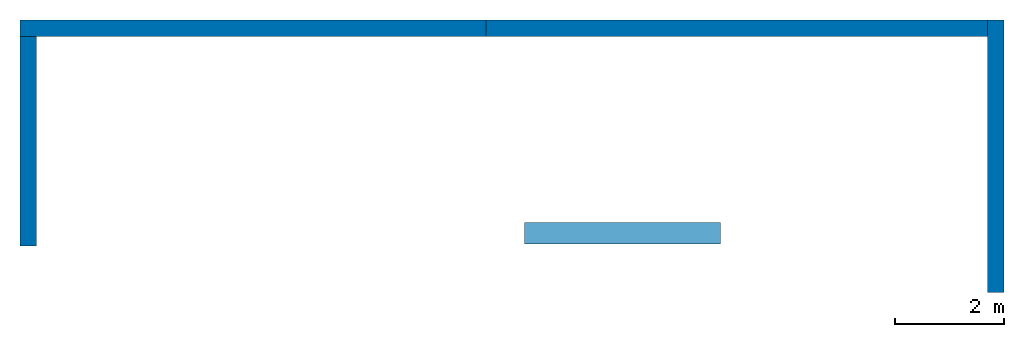
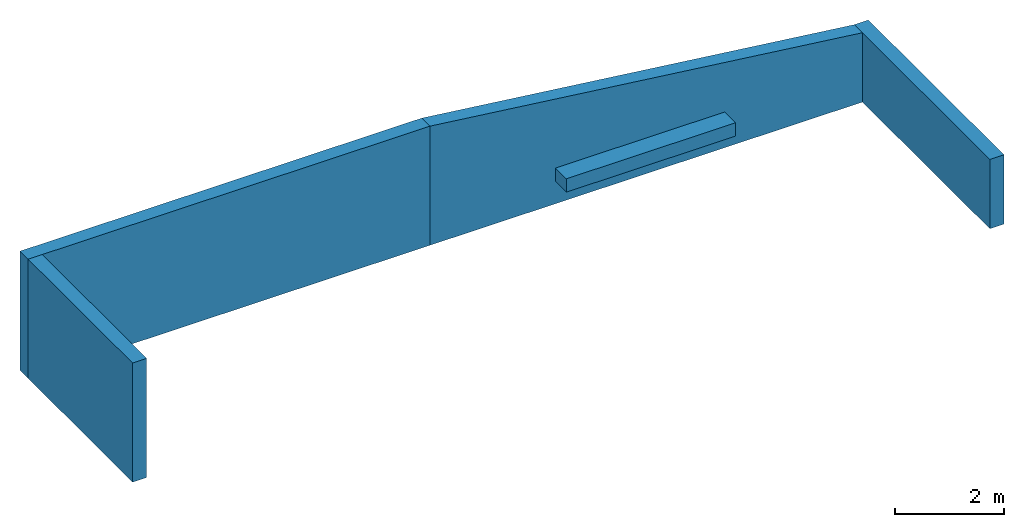
# Not in any storey: 4 walls, 1 beam.
"""IFC4 building model written with IfcOpenShell, lengths in metres."""

from ifc_helpers import new_model, entity, si_unit, converted_unit, direction, frame, frame_2d, origin_with_axes, origin_2d_with_axis, place, context, subcontext, project, spatial, polyline, rectangle, outline, extrude, element, save


model = new_model("IFC4")

# Units and contexts
model_context = context("Model", 3, precision=1e-05, world=origin_with_axes(), true_north=direction((6.12323399573677e-17, 1.0)))
body_context = subcontext(model_context, "Body", "Model", "MODEL_VIEW")
ifc_project = project(units=[si_unit("LENGTHUNIT", "METRE"), si_unit("AREAUNIT", "SQUARE_METRE"), si_unit("VOLUMEUNIT", "CUBIC_METRE"), converted_unit("PLANEANGLEUNIT", "DEGREE", entity("IfcPlaneAngleMeasure", 0.017453292519943295), si_unit("PLANEANGLEUNIT", "RADIAN"), dimensions=[0, 0, 0, 0, 0, 0, 0])], contexts=[model_context])

# Site
site = spatial("IfcSite", under=ifc_project, CompositionType="COMPLEX")

# Beam
beam_placement = place(None, origin_with_axes())
element("IfcBeam", 1, at=beam_placement, inside=site, Name="TR337", PredefinedType="BEAM", context=body_context, shape_type="SweptSolid", body=[
    extrude(rectangle(XDim=0.4, YDim=0.3, at=frame_2d((1.95156391047391e-18, -6.07153216591883e-18), x_axis=(0.0, 1.0))), frame((11.94, -3.05, 3.41), z_axis=(-1.0, 0.0, 0.0), x_axis=(0.0, 0.0, -1.0)), (0.0, 0.0, 1.0), 3.6),
])

# Building
building = spatial("IfcBuilding", under=site, Name="Italian House", CompositionType="COMPLEX")

# Walls
placement = place(None, origin_with_axes())
element("IfcWall", 2, at=placement, inside=building, Name="Muro001", PredefinedType="MOVABLE", context=body_context, shape_type="SweptSolid", body=[
    extrude(rectangle(XDim=8.55, YDim=0.3, at=origin_2d_with_axis()), frame((3.365, 0.71, 0.0), z_axis=(0.0, 0.0, 1.0), x_axis=(1.0, 0.0, 0.0)), (0.0, 0.0, 1.0), 2.68),
])
element("IfcWall", 3, at=placement, inside=building, Name="Muro002", PredefinedType="MOVABLE", context=body_context, shape_type="SweptSolid", body=[
    extrude(rectangle(XDim=5.0, YDim=0.3, at=frame_2d((-3.63797880709171e-12, 0.0), x_axis=(0.0, 1.0))), frame((16.99, -1.64, -2.27e-16), z_axis=(0.0, 0.0, 1.0), x_axis=(1.0, 0.0, 0.0)), (0.0, 0.0, 1.0), 1.56),
])
element("IfcWall", 4, at=placement, inside=building, Name="Muro003", PredefinedType="MOVABLE", context=body_context, shape_type="SweptSolid", body=[
    extrude(rectangle(XDim=3.85, YDim=0.3, at=frame_2d((0.0, 0.0), x_axis=(0.0, 1.0))), frame((-0.76, -1.365, 0.0), z_axis=(0.0, 0.0, 1.0), x_axis=(1.0, 0.0, 0.0)), (0.0, 0.0, 1.0), 2.68),
])
element("IfcWall", 5, at=placement, inside=building, Name="Muro004", PredefinedType="SHEAR", context=body_context, shape_type="SweptSolid", body=[
    extrude(outline(polyline([(-4.19496855345912, 1.59534591194969), (-4.19496855345912, -1.08465408805031), (5.00503144654088, -1.08465408805031), (5.00503144654088, 0.475345911949686), (-4.19496855345912, 1.59534591194969)])), frame((11.8349685534591, 0.86, 1.08465408805031), z_axis=(3e-17, -1.0, -4.5e-34), x_axis=(1.0, 3e-17, -3e-17)), (-3e-17, 2e-16, 1.0), 0.3),
])

save(model, "model.ifc")
